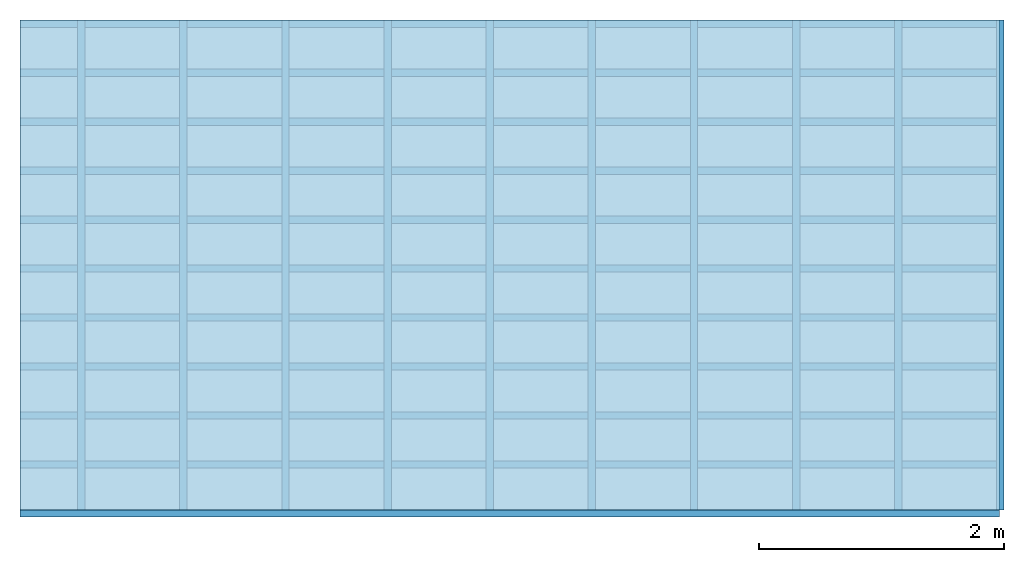
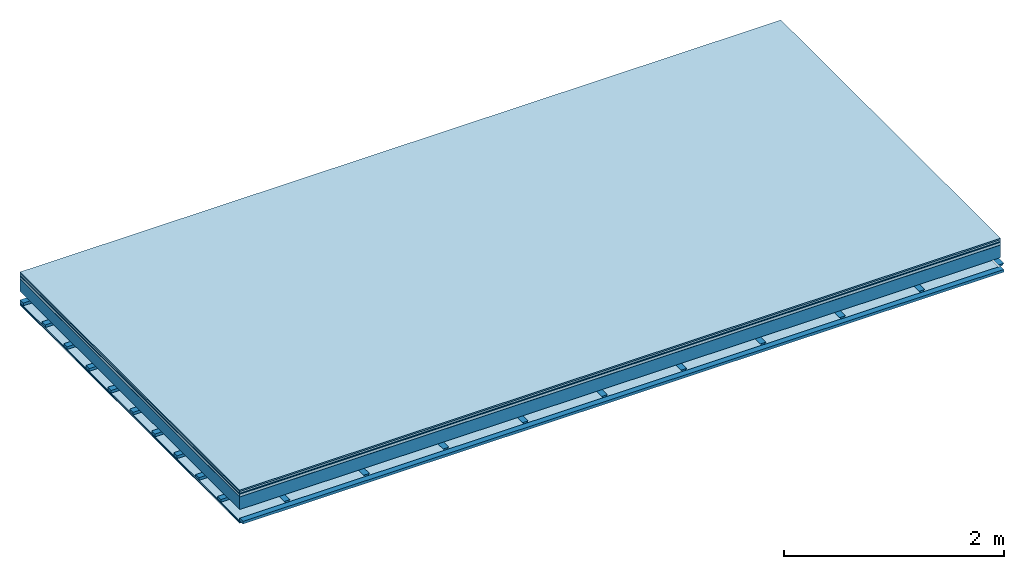
# One storey: 8 plates, 3 members, 1 element without a shape of its own.
"""IFC4 building model written with IfcOpenShell, lengths in metres."""

from ifc_helpers import new_model, si_unit, derived_unit, direction, frame, frame_2d, origin, origin_with_axes, place, context, project, spatial, polyline, rectangle, outline, extrude, material, layer, layer_set, type_object, element, aggregate, save


model = new_model("IFC4")

# Units and contexts
plan_context = context("Plan", 3, precision=1e-05, world=origin(), true_north=direction((0.0, 1.0)))
model_context = context("Model", 3, precision=1e-05, world=origin(), true_north=direction((0.0, 1.0)))
ifc_project = project(units=[si_unit("LENGTHUNIT", "METRE"), derived_unit("SOUNDPRESSUREUNIT", [(si_unit("PRESSUREUNIT", "PASCAL", prefix="MICRO"), 0)]), si_unit("ENERGYUNIT", "JOULE", prefix="MEGA"), si_unit("MASSUNIT", "GRAM", prefix="KILO"), derived_unit("THERMALTRANSMITTANCEUNIT", [(si_unit("POWERUNIT", "WATT"), 1), (si_unit("AREAUNIT", "SQUARE_METRE"), -1), (si_unit("THERMODYNAMICTEMPERATUREUNIT", "KELVIN"), -1)]), derived_unit("AREADENSITYUNIT", [(si_unit("MASSUNIT", "GRAM", prefix="KILO"), 1), (si_unit("AREAUNIT", "SQUARE_METRE"), -1)]), derived_unit("USERDEFINED", [(si_unit("ENERGYUNIT", "JOULE", prefix="MEGA"), 1), (si_unit("AREAUNIT", "SQUARE_METRE"), -1)])], contexts=[plan_context, model_context])

# Site, building, storey
site = spatial("IfcSite", under=ifc_project)
building_placement = place(None, origin())
building = spatial("IfcBuilding", under=site, at=building_placement)
storey_placement = place(building_placement, origin())
storey = spatial("IfcBuildingStorey", under=building, at=storey_placement)

# Slab, members, plates
ifc_material_1 = material(Category="11.013")
ifc_layer_1 = layer(ifc_material_1, 0.015, Name="Flooring")
ifc_material_2 = material(Category="03.007")
ifc_layer_2 = layer(ifc_material_2, 0.02, Name="On-material")
ifc_material_3 = material(Name="Wood fiber generic product", Category="10.009")
ifc_layer_3 = layer(ifc_material_3, 0.01, Name="Impact sound insulation")
ifc_material_4 = material(Name="with broken")
ifc_layer_4 = layer(ifc_material_4, 0.03, Name="on Supporting structure")
ifc_material_5 = material(Name="protection", Category="09.007")
ifc_layer_5 = layer(ifc_material_5, 0.0005, Name="Sub-floor")
ifc_material_6 = material(Name="no composite action")
ifc_layer_6 = layer(ifc_material_6, 0.0, Name="Bond")
ifc_layer_7 = layer(None, 0.14, Name="Supporting structure")
ifc_layer_8 = layer(ifc_material_6, 0.0, Name="Bond")
ifc_layer_9 = layer(None, 0.095, Name="Coupling")
ifc_layer_10 = layer(None, 0.03, Name="Battens / profiles")
ifc_material_7 = material(Name="Plasterboard type A", Category="03.008")
ifc_layer_11 = layer(ifc_material_7, 0.0125, Name="Ceiling covering 1st layer")
ifc_layer_12 = layer(ifc_material_7, 0.0125, Name="Ceiling covering layer 2")
ifc_material_8 = material(Category="04.001")
ifc_layer_13 = layer(ifc_material_8, 0.003, Name="Surface / treatment")
ifc_layer_set = layer_set([ifc_layer_1, ifc_layer_2, ifc_layer_3, ifc_layer_4, ifc_layer_5, ifc_layer_6, ifc_layer_7, ifc_layer_8, ifc_layer_9, ifc_layer_10, ifc_layer_11, ifc_layer_12, ifc_layer_13])
slab_type = type_object("IfcSlabType", Name="A2115", PredefinedType="NOTDEFINED", material=ifc_layer_set)
slab_placement = place(None, frame((0.0, 0.0, 0.0), z_axis=(0.0, 0.0, -1.0), x_axis=(1.0, 0.0, 0.0)))
slab = element("IfcSlab", 1, at=slab_placement, inside=storey, type_object=slab_type, material=ifc_layer_set, Name="Slab #1")
ifc_material_9 = material(Name="Solid timber panel")
member_1_placement = place(slab_placement, origin())
member_1 = element("IfcMember", 2, at=member_1_placement, material=ifc_material_9, Name="Supporting structure", context=plan_context, shape_type="SweptSolid", body=[
    extrude(rectangle(XDim=1.0, YDim=0.14, at=frame_2d((0.5, 0.07), x_axis=(1.0, 0.0))), frame((0.0, 4.0, 0.0755), z_axis=(0.0, -1.0, 0.0), x_axis=(1.0, 0.0, 0.0)), (0.0, 0.0, 1.0), 4.0),
    extrude(rectangle(XDim=1.0, YDim=0.14, at=frame_2d((0.5, 0.07), x_axis=(1.0, 0.0))), frame((1.0, 4.0, 0.0755), z_axis=(0.0, -1.0, 0.0), x_axis=(1.0, 0.0, 0.0)), (0.0, 0.0, 1.0), 4.0),
    extrude(rectangle(XDim=1.0, YDim=0.14, at=frame_2d((0.5, 0.07), x_axis=(1.0, 0.0))), frame((2.0, 4.0, 0.0755), z_axis=(0.0, -1.0, 0.0), x_axis=(1.0, 0.0, 0.0)), (0.0, 0.0, 1.0), 4.0),
    extrude(rectangle(XDim=1.0, YDim=0.14, at=frame_2d((0.5, 0.07), x_axis=(1.0, 0.0))), frame((3.0, 4.0, 0.0755), z_axis=(0.0, -1.0, 0.0), x_axis=(1.0, 0.0, 0.0)), (0.0, 0.0, 1.0), 4.0),
    extrude(rectangle(XDim=1.0, YDim=0.14, at=frame_2d((0.5, 0.07), x_axis=(1.0, 0.0))), frame((4.0, 4.0, 0.0755), z_axis=(0.0, -1.0, 0.0), x_axis=(1.0, 0.0, 0.0)), (0.0, 0.0, 1.0), 4.0),
    extrude(rectangle(XDim=1.0, YDim=0.14, at=frame_2d((0.5, 0.07), x_axis=(1.0, 0.0))), frame((5.0, 4.0, 0.0755), z_axis=(0.0, -1.0, 0.0), x_axis=(1.0, 0.0, 0.0)), (0.0, 0.0, 1.0), 4.0),
    extrude(rectangle(XDim=1.0, YDim=0.14, at=frame_2d((0.5, 0.07), x_axis=(1.0, 0.0))), frame((6.0, 4.0, 0.0755), z_axis=(0.0, -1.0, 0.0), x_axis=(1.0, 0.0, 0.0)), (0.0, 0.0, 1.0), 4.0),
    extrude(rectangle(XDim=1.0, YDim=0.14, at=frame_2d((0.5, 0.07), x_axis=(1.0, 0.0))), frame((7.0, 4.0, 0.0755), z_axis=(0.0, -1.0, 0.0), x_axis=(1.0, 0.0, 0.0)), (0.0, 0.0, 1.0), 4.0),
])
ifc_material_10 = material()
member_2_placement = place(slab_placement, origin())
member_2 = element("IfcMember", 3, at=member_2_placement, material=ifc_material_10, Name="Coupling", context=plan_context, shape_type="SweptSolid", body=[
    extrude(outline(polyline([(0.0, 0.0), (0.06, 0.0), (0.04, 0.02), (0.02, 0.02), (0.0, 0.0)])), frame((0.47, 4.0, 0.2905), z_axis=(0.0, -1.0, 0.0), x_axis=(1.0, 0.0, 0.0)), (0.0, 0.0, 1.0), 4.0),
    extrude(outline(polyline([(0.0, 0.0), (0.06, 0.0), (0.04, 0.02), (0.02, 0.02), (0.0, 0.0)])), frame((1.304, 4.0, 0.2905), z_axis=(0.0, -1.0, 0.0), x_axis=(1.0, 0.0, 0.0)), (0.0, 0.0, 1.0), 4.0),
    extrude(outline(polyline([(0.0, 0.0), (0.06, 0.0), (0.04, 0.02), (0.02, 0.02), (0.0, 0.0)])), frame((2.138, 4.0, 0.2905), z_axis=(0.0, -1.0, 0.0), x_axis=(1.0, 0.0, 0.0)), (0.0, 0.0, 1.0), 4.0),
    extrude(outline(polyline([(0.0, 0.0), (0.06, 0.0), (0.04, 0.02), (0.02, 0.02), (0.0, 0.0)])), frame((2.972, 4.0, 0.2905), z_axis=(0.0, -1.0, 0.0), x_axis=(1.0, 0.0, 0.0)), (0.0, 0.0, 1.0), 4.0),
    extrude(outline(polyline([(0.0, 0.0), (0.06, 0.0), (0.04, 0.02), (0.02, 0.02), (0.0, 0.0)])), frame((3.806, 4.0, 0.2905), z_axis=(0.0, -1.0, 0.0), x_axis=(1.0, 0.0, 0.0)), (0.0, 0.0, 1.0), 4.0),
    extrude(outline(polyline([(0.0, 0.0), (0.06, 0.0), (0.04, 0.02), (0.02, 0.02), (0.0, 0.0)])), frame((4.64, 4.0, 0.2905), z_axis=(0.0, -1.0, 0.0), x_axis=(1.0, 0.0, 0.0)), (0.0, 0.0, 1.0), 4.0),
    extrude(outline(polyline([(0.0, 0.0), (0.06, 0.0), (0.04, 0.02), (0.02, 0.02), (0.0, 0.0)])), frame((5.474, 4.0, 0.2905), z_axis=(0.0, -1.0, 0.0), x_axis=(1.0, 0.0, 0.0)), (0.0, 0.0, 1.0), 4.0),
    extrude(outline(polyline([(0.0, 0.0), (0.06, 0.0), (0.04, 0.02), (0.02, 0.02), (0.0, 0.0)])), frame((6.308, 4.0, 0.2905), z_axis=(0.0, -1.0, 0.0), x_axis=(1.0, 0.0, 0.0)), (0.0, 0.0, 1.0), 4.0),
    extrude(outline(polyline([(0.0, 0.0), (0.06, 0.0), (0.04, 0.02), (0.02, 0.02), (0.0, 0.0)])), frame((7.142, 4.0, 0.2905), z_axis=(0.0, -1.0, 0.0), x_axis=(1.0, 0.0, 0.0)), (0.0, 0.0, 1.0), 4.0),
    extrude(outline(polyline([(0.0, 0.0), (0.06, 0.0), (0.04, 0.02), (0.02, 0.02), (0.0, 0.0)])), frame((7.976, 4.0, 0.2905), z_axis=(0.0, -1.0, 0.0), x_axis=(1.0, 0.0, 0.0)), (0.0, 0.0, 1.0), 4.0),
])
member_3_placement = place(slab_placement, origin())
member_3 = element("IfcMember", 4, at=member_3_placement, material=ifc_material_10, Name="Battens / profiles", context=plan_context, shape_type="SweptSolid", body=[
    extrude(rectangle(XDim=0.06, YDim=0.03, at=frame_2d((0.03, 0.015), x_axis=(1.0, 0.0))), frame((0.0, 0.0, 0.3105), z_axis=(1.0, 0.0, 0.0), x_axis=(0.0, 1.0, 0.0)), (0.0, 0.0, 1.0), 8.0),
    extrude(rectangle(XDim=0.06, YDim=0.03, at=frame_2d((0.03, 0.015), x_axis=(1.0, 0.0))), frame((0.0, 0.4, 0.3105), z_axis=(1.0, 0.0, 0.0), x_axis=(0.0, 1.0, 0.0)), (0.0, 0.0, 1.0), 8.0),
    extrude(rectangle(XDim=0.06, YDim=0.03, at=frame_2d((0.03, 0.015), x_axis=(1.0, 0.0))), frame((0.0, 0.8, 0.3105), z_axis=(1.0, 0.0, 0.0), x_axis=(0.0, 1.0, 0.0)), (0.0, 0.0, 1.0), 8.0),
    extrude(rectangle(XDim=0.06, YDim=0.03, at=frame_2d((0.03, 0.015), x_axis=(1.0, 0.0))), frame((0.0, 1.2, 0.3105), z_axis=(1.0, 0.0, 0.0), x_axis=(0.0, 1.0, 0.0)), (0.0, 0.0, 1.0), 8.0),
    extrude(rectangle(XDim=0.06, YDim=0.03, at=frame_2d((0.03, 0.015), x_axis=(1.0, 0.0))), frame((0.0, 1.6, 0.3105), z_axis=(1.0, 0.0, 0.0), x_axis=(0.0, 1.0, 0.0)), (0.0, 0.0, 1.0), 8.0),
    extrude(rectangle(XDim=0.06, YDim=0.03, at=frame_2d((0.03, 0.015), x_axis=(1.0, 0.0))), frame((0.0, 2.0, 0.3105), z_axis=(1.0, 0.0, 0.0), x_axis=(0.0, 1.0, 0.0)), (0.0, 0.0, 1.0), 8.0),
    extrude(rectangle(XDim=0.06, YDim=0.03, at=frame_2d((0.03, 0.015), x_axis=(1.0, 0.0))), frame((0.0, 2.4, 0.3105), z_axis=(1.0, 0.0, 0.0), x_axis=(0.0, 1.0, 0.0)), (0.0, 0.0, 1.0), 8.0),
    extrude(rectangle(XDim=0.06, YDim=0.03, at=frame_2d((0.03, 0.015), x_axis=(1.0, 0.0))), frame((0.0, 2.8, 0.3105), z_axis=(1.0, 0.0, 0.0), x_axis=(0.0, 1.0, 0.0)), (0.0, 0.0, 1.0), 8.0),
    extrude(rectangle(XDim=0.06, YDim=0.03, at=frame_2d((0.03, 0.015), x_axis=(1.0, 0.0))), frame((0.0, 3.2, 0.3105), z_axis=(1.0, 0.0, 0.0), x_axis=(0.0, 1.0, 0.0)), (0.0, 0.0, 1.0), 8.0),
    extrude(rectangle(XDim=0.06, YDim=0.03, at=frame_2d((0.03, 0.015), x_axis=(1.0, 0.0))), frame((0.0, 3.6, 0.3105), z_axis=(1.0, 0.0, 0.0), x_axis=(0.0, 1.0, 0.0)), (0.0, 0.0, 1.0), 8.0),
    extrude(rectangle(XDim=0.06, YDim=0.03, at=frame_2d((0.03, 0.015), x_axis=(1.0, 0.0))), frame((0.0, 4.0, 0.3105), z_axis=(1.0, 0.0, 0.0), x_axis=(0.0, 1.0, 0.0)), (0.0, 0.0, 1.0), 8.0),
])
plate_1_placement = place(slab_placement, origin())
plate_1 = element("IfcPlate", 5, at=plate_1_placement, material=ifc_material_1, Name="Flooring", context=plan_context, shape_type="SweptSolid", body=[
    extrude(rectangle(XDim=8.0, YDim=4.0, at=frame_2d((4.0, 2.0), x_axis=(1.0, 0.0))), origin_with_axes(), (0.0, 0.0, 1.0), 0.015),
])
plate_2_placement = place(slab_placement, origin())
plate_2 = element("IfcPlate", 6, at=plate_2_placement, material=ifc_material_2, Name="On-material", context=plan_context, shape_type="SweptSolid", body=[
    extrude(rectangle(XDim=8.0, YDim=4.0, at=frame_2d((4.0, 2.0), x_axis=(1.0, 0.0))), frame((0.0, 0.0, 0.015), z_axis=(0.0, 0.0, 1.0), x_axis=(1.0, 0.0, 0.0)), (0.0, 0.0, 1.0), 0.02),
])
plate_3_placement = place(slab_placement, origin())
plate_3 = element("IfcPlate", 7, at=plate_3_placement, material=ifc_material_3, Name="Impact sound insulation", context=plan_context, shape_type="SweptSolid", body=[
    extrude(rectangle(XDim=8.0, YDim=4.0, at=frame_2d((4.0, 2.0), x_axis=(1.0, 0.0))), frame((0.0, 0.0, 0.035), z_axis=(0.0, 0.0, 1.0), x_axis=(1.0, 0.0, 0.0)), (0.0, 0.0, 1.0), 0.01),
])
plate_4_placement = place(slab_placement, origin())
plate_4 = element("IfcPlate", 8, at=plate_4_placement, material=ifc_material_4, Name="on Supporting structure", context=plan_context, shape_type="SweptSolid", body=[
    extrude(rectangle(XDim=8.0, YDim=4.0, at=frame_2d((4.0, 2.0), x_axis=(1.0, 0.0))), frame((0.0, 0.0, 0.045), z_axis=(0.0, 0.0, 1.0), x_axis=(1.0, 0.0, 0.0)), (0.0, 0.0, 1.0), 0.03),
])
plate_5_placement = place(slab_placement, origin())
plate_5 = element("IfcPlate", 9, at=plate_5_placement, material=ifc_material_5, Name="Sub-floor", context=plan_context, shape_type="SweptSolid", body=[
    extrude(rectangle(XDim=8.0, YDim=4.0, at=frame_2d((4.0, 2.0), x_axis=(1.0, 0.0))), frame((0.0, 0.0, 0.075), z_axis=(0.0, 0.0, 1.0), x_axis=(1.0, 0.0, 0.0)), (0.0, 0.0, 1.0), 0.0005),
])
plate_6_placement = place(slab_placement, origin())
plate_6 = element("IfcPlate", 10, at=plate_6_placement, material=ifc_material_7, Name="Ceiling covering 1st layer", context=plan_context, shape_type="SweptSolid", body=[
    extrude(rectangle(XDim=8.0, YDim=4.0, at=frame_2d((4.0, 2.0), x_axis=(1.0, 0.0))), frame((0.0, 0.0, 0.3405), z_axis=(0.0, 0.0, 1.0), x_axis=(1.0, 0.0, 0.0)), (0.0, 0.0, 1.0), 0.0125),
])
plate_7_placement = place(slab_placement, origin())
plate_7 = element("IfcPlate", 11, at=plate_7_placement, material=ifc_material_7, Name="Ceiling covering layer 2", context=plan_context, shape_type="SweptSolid", body=[
    extrude(rectangle(XDim=8.0, YDim=4.0, at=frame_2d((4.0, 2.0), x_axis=(1.0, 0.0))), frame((0.0, 0.0, 0.353), z_axis=(0.0, 0.0, 1.0), x_axis=(1.0, 0.0, 0.0)), (0.0, 0.0, 1.0), 0.0125),
])
plate_8_placement = place(slab_placement, origin())
plate_8 = element("IfcPlate", 12, at=plate_8_placement, material=ifc_material_8, Name="Surface / treatment", context=plan_context, shape_type="SweptSolid", body=[
    extrude(rectangle(XDim=8.0, YDim=4.0, at=frame_2d((4.0, 2.0), x_axis=(1.0, 0.0))), frame((0.0, 0.0, 0.3655), z_axis=(0.0, 0.0, 1.0), x_axis=(1.0, 0.0, 0.0)), (0.0, 0.0, 1.0), 0.003),
])
aggregate(slab, [plate_1, plate_2, plate_3, plate_4, plate_5, member_1, member_2, member_3, plate_6, plate_7, plate_8])

save(model, "model.ifc")
